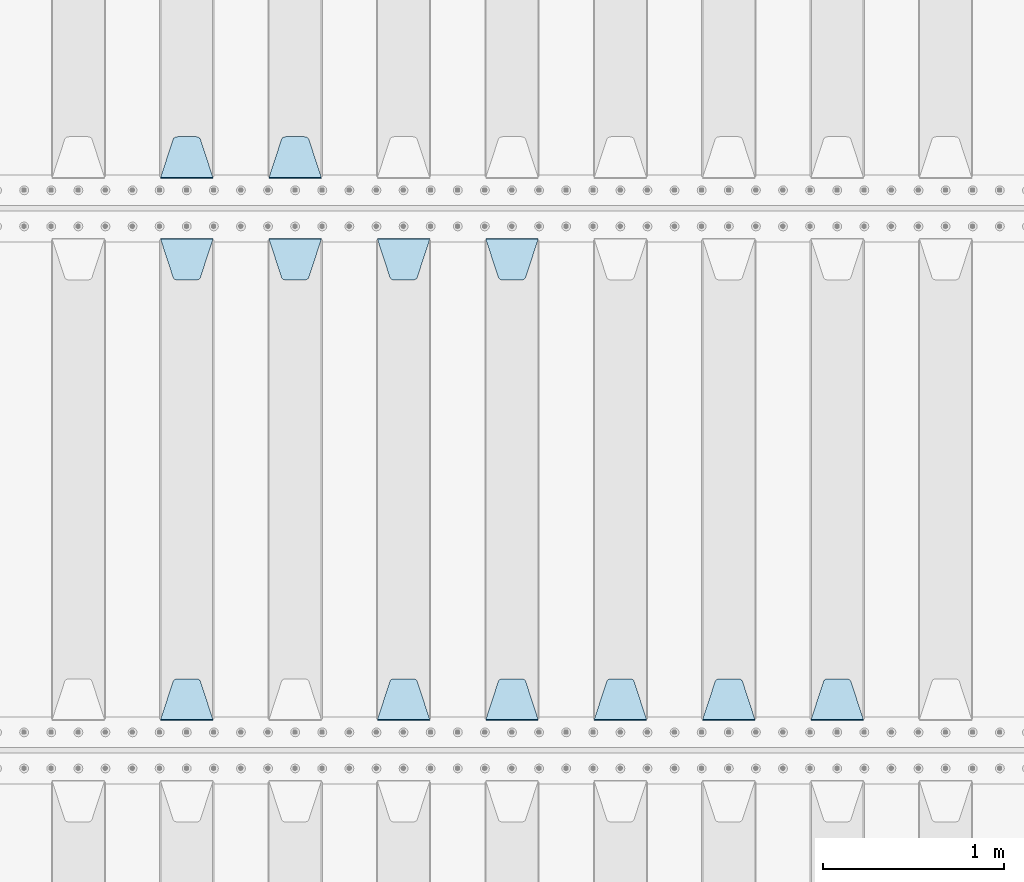
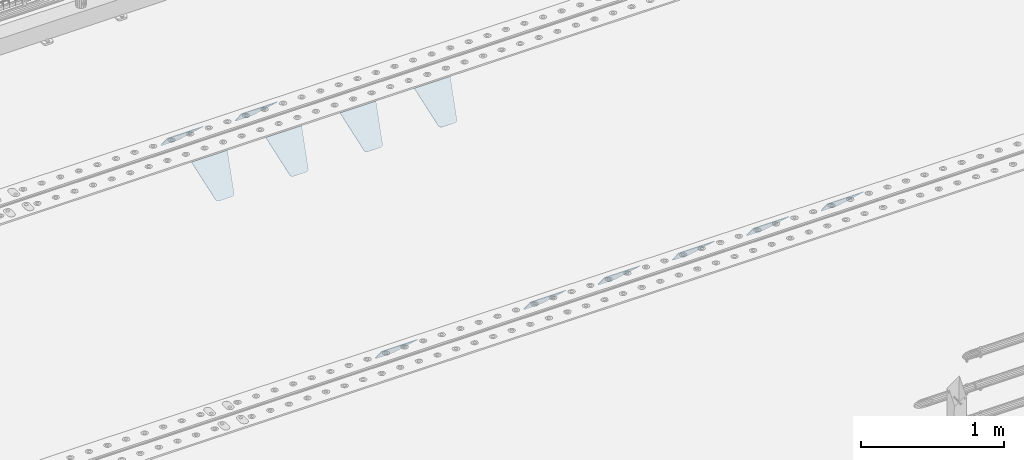
# One storey, part 208 of 247: 12 plates.
"""IFC2X3 building model written with IfcOpenShell, lengths in millimetres."""

from ifc_helpers import new_model, si_unit, frame, origin_with_axes, place, context, subcontext, project, spatial, faceted_brep, material, type_object, element, save


model = new_model("IFC2X3")

# Units and contexts
model_context = context("Model", 3, precision=1e-05, world=origin_with_axes())
body_context = subcontext(model_context, "Body", "Model", "MODEL_VIEW")
ifc_project = project(units=[si_unit("LENGTHUNIT", "METRE", prefix="MILLI"), si_unit("AREAUNIT", "SQUARE_METRE"), si_unit("VOLUMEUNIT", "CUBIC_METRE"), si_unit("MASSUNIT", "GRAM", prefix="KILO"), si_unit("TIMEUNIT", "SECOND"), si_unit("PLANEANGLEUNIT", "RADIAN"), si_unit("SOLIDANGLEUNIT", "STERADIAN"), si_unit("THERMODYNAMICTEMPERATUREUNIT", "DEGREE_CELSIUS"), si_unit("LUMINOUSINTENSITYUNIT", "LUMEN")], contexts=[model_context])

# Site, building, storey
site_placement = place(None, origin_with_axes())
site = spatial("IfcSite", under=ifc_project, at=site_placement, CompositionType="ELEMENT")
building_placement = place(site_placement, origin_with_axes())
building = spatial("IfcBuilding", under=site, at=building_placement, Name="Standard", CompositionType="ELEMENT")
storey_placement = place(building_placement, origin_with_axes())
storey = spatial("IfcBuildingStorey", under=building, at=storey_placement, Name="Undefined", CompositionType="ELEMENT", Elevation=0.0)

# Plates
ifc_material = material(Name="STEEL/S355N")
plate_type = type_object("IfcPlateType", PredefinedType="NOTDEFINED")
plate_1_placement = place(storey_placement, frame((10745.0, 3168.23223304703, -1.76776695296758), z_axis=(0.0, 0.707106781186548, -0.707106781186547), x_axis=(-1.0, 0.0, 0.0)))
element("IfcPlate", 1, at=plate_1_placement, inside=storey, type_object=plate_type, material=ifc_material, context=body_context, shape_type="Brep", body=[
    faceted_brep([(0.0, -2.49999999999909, 0.0), (69.345504679477, -2.5, 300.17173142483), (69.345504679477, 2.50000000000091, 300.171731424831), (0.0, 2.5, -9.09494701772928e-13), (70.9274061199576, -2.5, 304.897442415399), (70.9274061199576, 2.50000000000091, 304.8974424154), (73.3818627772307, -2.49999999999909, 309.234538108527), (73.3818627772307, 2.5, 309.234538108526), (76.6187032999551, -2.5, 313.023683126102), (76.6187032999551, 2.50000000000091, 313.023683126102), (80.5190132704993, -2.49999999999909, 316.125672595371), (80.5190132704993, 2.50000000000091, 316.125672595372), (84.9395038596849, -2.49999999999909, 318.426546230476), (84.9395038596849, 2.5, 318.426546230475), (89.7177759439219, -2.5, 319.841774983274), (89.7177759439219, 2.50000000000091, 319.841774983275), (94.678286292652, -2.5, 320.319366455077), (94.678286292652, 2.50000000000091, 320.319366455077), (195.321713707348, -2.5, 320.319366455077), (195.321713707348, 2.50000000000091, 320.319366455077), (200.282224056078, -2.5, 319.841774983274), (200.282224056078, 2.50000000000091, 319.841774983275), (205.060496140315, -2.5, 318.426546230475), (205.060496140315, 2.5, 318.426546230474), (209.480986729501, -2.49999999999818, 316.12567259537), (209.480986729501, 2.50000000000091, 316.12567259537), (213.381296700045, -2.5, 313.023683126101), (213.381296700045, 2.50000000000091, 313.023683126101), (216.618137222769, -2.5, 309.234538108525), (216.618137222769, 2.5, 309.234538108525), (219.072593880042, -2.49999999999909, 304.897442415398), (219.072593880042, 2.5, 304.897442415398), (220.654495320523, -2.5, 300.17173142483), (220.654495320523, 2.50000000000091, 300.171731424831), (290.0, -2.49999999999909, 0.0), (290.0, 2.5, -9.09494701772928e-13)], [[[0, 1, 2, 3]], [[1, 4, 5, 2]], [[4, 6, 7, 5]], [[6, 8, 9, 7]], [[8, 10, 11, 9]], [[10, 12, 13, 11]], [[12, 14, 15, 13]], [[14, 16, 17, 15]], [[16, 18, 19, 17]], [[18, 20, 21, 19]], [[20, 22, 23, 21]], [[22, 24, 25, 23]], [[24, 26, 27, 25]], [[26, 28, 29, 27]], [[28, 30, 31, 29]], [[30, 32, 33, 31]], [[32, 34, 35, 33]], [[34, 0, 3, 35]], [[5, 7, 9, 11, 13, 15, 17, 19, 21, 23, 25, 27, 29, 31, 33, 35, 3, 2]], [[34, 32, 30, 28, 26, 24, 22, 20, 18, 16, 14, 12, 10, 8, 6, 4, 1, 0]]]),
])
plate_2_placement = place(storey_placement, frame((10145.0, 3168.23223304703, -1.76776695296758), z_axis=(0.0, 0.707106781186548, -0.707106781186547), x_axis=(-1.0, 0.0, 0.0)))
element("IfcPlate", 2, at=plate_2_placement, inside=storey, type_object=plate_type, material=ifc_material, context=body_context, shape_type="Brep", body=[
    faceted_brep([(0.0, -2.49999999999909, 0.0), (69.345504679477, -2.5, 300.17173142483), (69.345504679477, 2.50000000000091, 300.171731424831), (0.0, 2.5, -9.09494701772928e-13), (70.9274061199576, -2.5, 304.897442415399), (70.9274061199576, 2.50000000000091, 304.8974424154), (73.3818627772307, -2.49999999999909, 309.234538108527), (73.3818627772307, 2.5, 309.234538108526), (76.6187032999551, -2.5, 313.023683126102), (76.6187032999551, 2.50000000000091, 313.023683126102), (80.5190132704993, -2.49999999999909, 316.125672595371), (80.5190132704993, 2.50000000000091, 316.125672595372), (84.9395038596849, -2.49999999999909, 318.426546230476), (84.9395038596849, 2.5, 318.426546230475), (89.7177759439219, -2.5, 319.841774983274), (89.7177759439219, 2.50000000000091, 319.841774983275), (94.678286292652, -2.5, 320.319366455077), (94.678286292652, 2.50000000000091, 320.319366455077), (195.321713707348, -2.5, 320.319366455077), (195.321713707348, 2.50000000000091, 320.319366455077), (200.282224056078, -2.5, 319.841774983274), (200.282224056078, 2.50000000000091, 319.841774983275), (205.060496140315, -2.5, 318.426546230475), (205.060496140315, 2.5, 318.426546230474), (209.480986729501, -2.49999999999818, 316.12567259537), (209.480986729501, 2.50000000000091, 316.12567259537), (213.381296700045, -2.5, 313.023683126101), (213.381296700045, 2.50000000000091, 313.023683126101), (216.618137222769, -2.5, 309.234538108525), (216.618137222769, 2.5, 309.234538108525), (219.072593880042, -2.49999999999909, 304.897442415398), (219.072593880042, 2.5, 304.897442415398), (220.654495320523, -2.5, 300.17173142483), (220.654495320523, 2.50000000000091, 300.171731424831), (290.0, -2.49999999999909, 0.0), (290.0, 2.5, -9.09494701772928e-13)], [[[0, 1, 2, 3]], [[1, 4, 5, 2]], [[4, 6, 7, 5]], [[6, 8, 9, 7]], [[8, 10, 11, 9]], [[10, 12, 13, 11]], [[12, 14, 15, 13]], [[14, 16, 17, 15]], [[16, 18, 19, 17]], [[18, 20, 21, 19]], [[20, 22, 23, 21]], [[22, 24, 25, 23]], [[24, 26, 27, 25]], [[26, 28, 29, 27]], [[28, 30, 31, 29]], [[30, 32, 33, 31]], [[32, 34, 35, 33]], [[34, 0, 3, 35]], [[5, 7, 9, 11, 13, 15, 17, 19, 21, 23, 25, 27, 29, 31, 33, 35, 3, 2]], [[34, 32, 30, 28, 26, 24, 22, 20, 18, 16, 14, 12, 10, 8, 6, 4, 1, 0]]]),
])
plate_3_placement = place(storey_placement, frame((9545.0, 3168.23223304703, -1.76776695296758), z_axis=(0.0, 0.707106781186548, -0.707106781186547), x_axis=(-1.0, 0.0, 0.0)))
element("IfcPlate", 3, at=plate_3_placement, inside=storey, type_object=plate_type, material=ifc_material, context=body_context, shape_type="Brep", body=[
    faceted_brep([(0.0, -2.49999999999909, 0.0), (69.345504679477, -2.5, 300.17173142483), (69.345504679477, 2.50000000000091, 300.171731424831), (0.0, 2.5, -9.09494701772928e-13), (70.9274061199576, -2.5, 304.897442415399), (70.9274061199576, 2.50000000000091, 304.8974424154), (73.3818627772307, -2.49999999999909, 309.234538108527), (73.3818627772307, 2.5, 309.234538108526), (76.6187032999551, -2.5, 313.023683126102), (76.6187032999551, 2.50000000000091, 313.023683126102), (80.5190132704993, -2.49999999999909, 316.125672595371), (80.5190132704993, 2.50000000000091, 316.125672595372), (84.9395038596849, -2.49999999999909, 318.426546230476), (84.9395038596849, 2.5, 318.426546230475), (89.7177759439219, -2.5, 319.841774983274), (89.7177759439219, 2.50000000000091, 319.841774983275), (94.678286292652, -2.5, 320.319366455077), (94.678286292652, 2.50000000000091, 320.319366455077), (195.321713707348, -2.5, 320.319366455077), (195.321713707348, 2.50000000000091, 320.319366455077), (200.282224056078, -2.5, 319.841774983274), (200.282224056078, 2.50000000000091, 319.841774983275), (205.060496140315, -2.5, 318.426546230475), (205.060496140315, 2.5, 318.426546230474), (209.480986729501, -2.49999999999818, 316.12567259537), (209.480986729501, 2.50000000000091, 316.12567259537), (213.381296700045, -2.5, 313.023683126101), (213.381296700045, 2.50000000000091, 313.023683126101), (216.618137222769, -2.5, 309.234538108525), (216.618137222769, 2.5, 309.234538108525), (219.072593880042, -2.49999999999909, 304.897442415398), (219.072593880042, 2.5, 304.897442415398), (220.654495320523, -2.5, 300.17173142483), (220.654495320523, 2.50000000000091, 300.171731424831), (290.0, -2.49999999999909, 0.0), (290.0, 2.5, -9.09494701772928e-13)], [[[0, 1, 2, 3]], [[1, 4, 5, 2]], [[4, 6, 7, 5]], [[6, 8, 9, 7]], [[8, 10, 11, 9]], [[10, 12, 13, 11]], [[12, 14, 15, 13]], [[14, 16, 17, 15]], [[16, 18, 19, 17]], [[18, 20, 21, 19]], [[20, 22, 23, 21]], [[22, 24, 25, 23]], [[24, 26, 27, 25]], [[26, 28, 29, 27]], [[28, 30, 31, 29]], [[30, 32, 33, 31]], [[32, 34, 35, 33]], [[34, 0, 3, 35]], [[5, 7, 9, 11, 13, 15, 17, 19, 21, 23, 25, 27, 29, 31, 33, 35, 3, 2]], [[34, 32, 30, 28, 26, 24, 22, 20, 18, 16, 14, 12, 10, 8, 6, 4, 1, 0]]]),
])
plate_4_placement = place(storey_placement, frame((8655.0, 5831.76776695594, -1.767766952965), z_axis=(0.0, -0.707106781186548, -0.707106781186547), x_axis=(1.0, 0.0, 0.0)))
element("IfcPlate", 4, at=plate_4_placement, inside=storey, type_object=plate_type, material=ifc_material, context=body_context, shape_type="Brep", body=[
    faceted_brep([(0.0, -2.49999999999909, 0.0), (69.345504679477, -2.5, 300.17173142483), (69.345504679477, 2.50000000000091, 300.171731424831), (0.0, 2.5, -9.09494701772928e-13), (70.9274061199576, -2.5, 304.897442415399), (70.9274061199576, 2.50000000000091, 304.8974424154), (73.3818627772307, -2.49999999999909, 309.234538108527), (73.3818627772307, 2.5, 309.234538108526), (76.6187032999551, -2.5, 313.023683126102), (76.6187032999551, 2.50000000000091, 313.023683126102), (80.5190132704993, -2.49999999999909, 316.125672595371), (80.5190132704993, 2.50000000000091, 316.125672595372), (84.9395038596849, -2.49999999999909, 318.426546230476), (84.9395038596849, 2.5, 318.426546230475), (89.7177759439219, -2.5, 319.841774983274), (89.7177759439219, 2.50000000000091, 319.841774983275), (94.678286292652, -2.5, 320.319366455077), (94.678286292652, 2.50000000000091, 320.319366455077), (195.321713707348, -2.5, 320.319366455077), (195.321713707348, 2.50000000000091, 320.319366455077), (200.282224056078, -2.5, 319.841774983274), (200.282224056078, 2.50000000000091, 319.841774983275), (205.060496140315, -2.5, 318.426546230475), (205.060496140315, 2.5, 318.426546230474), (209.480986729501, -2.49999999999818, 316.12567259537), (209.480986729501, 2.50000000000091, 316.12567259537), (213.381296700045, -2.5, 313.023683126101), (213.381296700045, 2.50000000000091, 313.023683126101), (216.618137222769, -2.5, 309.234538108525), (216.618137222769, 2.5, 309.234538108525), (219.072593880042, -2.49999999999909, 304.897442415398), (219.072593880042, 2.5, 304.897442415398), (220.654495320523, -2.5, 300.17173142483), (220.654495320523, 2.50000000000091, 300.171731424831), (290.0, -2.49999999999909, 0.0), (290.0, 2.5, -9.09494701772928e-13)], [[[0, 1, 2, 3]], [[1, 4, 5, 2]], [[4, 6, 7, 5]], [[6, 8, 9, 7]], [[8, 10, 11, 9]], [[10, 12, 13, 11]], [[12, 14, 15, 13]], [[14, 16, 17, 15]], [[16, 18, 19, 17]], [[18, 20, 21, 19]], [[20, 22, 23, 21]], [[22, 24, 25, 23]], [[24, 26, 27, 25]], [[26, 28, 29, 27]], [[28, 30, 31, 29]], [[30, 32, 33, 31]], [[32, 34, 35, 33]], [[34, 0, 3, 35]], [[5, 7, 9, 11, 13, 15, 17, 19, 21, 23, 25, 27, 29, 31, 33, 35, 3, 2]], [[34, 32, 30, 28, 26, 24, 22, 20, 18, 16, 14, 12, 10, 8, 6, 4, 1, 0]]]),
])
plate_5_placement = place(storey_placement, frame((8945.0, 3168.23223304703, -1.76776695296758), z_axis=(0.0, 0.707106781186548, -0.707106781186547), x_axis=(-1.0, 0.0, 0.0)))
element("IfcPlate", 5, at=plate_5_placement, inside=storey, type_object=plate_type, material=ifc_material, context=body_context, shape_type="Brep", body=[
    faceted_brep([(0.0, -2.49999999999909, 0.0), (69.345504679477, -2.5, 300.17173142483), (69.345504679477, 2.50000000000091, 300.171731424831), (0.0, 2.5, -9.09494701772928e-13), (70.9274061199576, -2.5, 304.897442415399), (70.9274061199576, 2.50000000000091, 304.8974424154), (73.3818627772307, -2.49999999999909, 309.234538108527), (73.3818627772307, 2.5, 309.234538108526), (76.6187032999551, -2.5, 313.023683126102), (76.6187032999551, 2.50000000000091, 313.023683126102), (80.5190132704993, -2.49999999999909, 316.125672595371), (80.5190132704993, 2.50000000000091, 316.125672595372), (84.9395038596849, -2.49999999999909, 318.426546230476), (84.9395038596849, 2.5, 318.426546230475), (89.7177759439219, -2.5, 319.841774983274), (89.7177759439219, 2.50000000000091, 319.841774983275), (94.678286292652, -2.5, 320.319366455077), (94.678286292652, 2.50000000000091, 320.319366455077), (195.321713707348, -2.5, 320.319366455077), (195.321713707348, 2.50000000000091, 320.319366455077), (200.282224056078, -2.5, 319.841774983274), (200.282224056078, 2.50000000000091, 319.841774983275), (205.060496140315, -2.5, 318.426546230475), (205.060496140315, 2.5, 318.426546230474), (209.480986729501, -2.49999999999818, 316.12567259537), (209.480986729501, 2.50000000000091, 316.12567259537), (213.381296700045, -2.5, 313.023683126101), (213.381296700045, 2.50000000000091, 313.023683126101), (216.618137222769, -2.5, 309.234538108525), (216.618137222769, 2.5, 309.234538108525), (219.072593880042, -2.49999999999909, 304.897442415398), (219.072593880042, 2.5, 304.897442415398), (220.654495320523, -2.5, 300.17173142483), (220.654495320523, 2.50000000000091, 300.171731424831), (290.0, -2.49999999999909, 0.0), (290.0, 2.5, -9.09494701772928e-13)], [[[0, 1, 2, 3]], [[1, 4, 5, 2]], [[4, 6, 7, 5]], [[6, 8, 9, 7]], [[8, 10, 11, 9]], [[10, 12, 13, 11]], [[12, 14, 15, 13]], [[14, 16, 17, 15]], [[16, 18, 19, 17]], [[18, 20, 21, 19]], [[20, 22, 23, 21]], [[22, 24, 25, 23]], [[24, 26, 27, 25]], [[26, 28, 29, 27]], [[28, 30, 31, 29]], [[30, 32, 33, 31]], [[32, 34, 35, 33]], [[34, 0, 3, 35]], [[5, 7, 9, 11, 13, 15, 17, 19, 21, 23, 25, 27, 29, 31, 33, 35, 3, 2]], [[34, 32, 30, 28, 26, 24, 22, 20, 18, 16, 14, 12, 10, 8, 6, 4, 1, 0]]]),
])
plate_6_placement = place(storey_placement, frame((8055.0, 5831.76776695594, -1.767766952965), z_axis=(0.0, -0.707106781186548, -0.707106781186547), x_axis=(1.0, 0.0, 0.0)))
element("IfcPlate", 6, at=plate_6_placement, inside=storey, type_object=plate_type, material=ifc_material, context=body_context, shape_type="Brep", body=[
    faceted_brep([(0.0, -2.49999999999909, 0.0), (69.345504679477, -2.5, 300.17173142483), (69.345504679477, 2.50000000000091, 300.171731424831), (0.0, 2.5, -9.09494701772928e-13), (70.9274061199576, -2.5, 304.897442415399), (70.9274061199576, 2.50000000000091, 304.8974424154), (73.3818627772307, -2.49999999999909, 309.234538108527), (73.3818627772307, 2.5, 309.234538108526), (76.6187032999551, -2.5, 313.023683126102), (76.6187032999551, 2.50000000000091, 313.023683126102), (80.5190132704993, -2.49999999999909, 316.125672595371), (80.5190132704993, 2.50000000000091, 316.125672595372), (84.9395038596849, -2.49999999999909, 318.426546230476), (84.9395038596849, 2.5, 318.426546230475), (89.7177759439219, -2.5, 319.841774983274), (89.7177759439219, 2.50000000000091, 319.841774983275), (94.678286292652, -2.5, 320.319366455077), (94.678286292652, 2.50000000000091, 320.319366455077), (195.321713707348, -2.5, 320.319366455077), (195.321713707348, 2.50000000000091, 320.319366455077), (200.282224056078, -2.5, 319.841774983274), (200.282224056078, 2.50000000000091, 319.841774983275), (205.060496140315, -2.5, 318.426546230475), (205.060496140315, 2.5, 318.426546230474), (209.480986729501, -2.49999999999818, 316.12567259537), (209.480986729501, 2.50000000000091, 316.12567259537), (213.381296700045, -2.5, 313.023683126101), (213.381296700045, 2.50000000000091, 313.023683126101), (216.618137222769, -2.5, 309.234538108525), (216.618137222769, 2.5, 309.234538108525), (219.072593880042, -2.49999999999909, 304.897442415398), (219.072593880042, 2.5, 304.897442415398), (220.654495320523, -2.5, 300.17173142483), (220.654495320523, 2.50000000000091, 300.171731424831), (290.0, -2.49999999999909, 0.0), (290.0, 2.5, -9.09494701772928e-13)], [[[0, 1, 2, 3]], [[1, 4, 5, 2]], [[4, 6, 7, 5]], [[6, 8, 9, 7]], [[8, 10, 11, 9]], [[10, 12, 13, 11]], [[12, 14, 15, 13]], [[14, 16, 17, 15]], [[16, 18, 19, 17]], [[18, 20, 21, 19]], [[20, 22, 23, 21]], [[22, 24, 25, 23]], [[24, 26, 27, 25]], [[26, 28, 29, 27]], [[28, 30, 31, 29]], [[30, 32, 33, 31]], [[32, 34, 35, 33]], [[34, 0, 3, 35]], [[5, 7, 9, 11, 13, 15, 17, 19, 21, 23, 25, 27, 29, 31, 33, 35, 3, 2]], [[34, 32, 30, 28, 26, 24, 22, 20, 18, 16, 14, 12, 10, 8, 6, 4, 1, 0]]]),
])
plate_7_placement = place(storey_placement, frame((8345.0, 3168.23223304703, -1.76776695296758), z_axis=(0.0, 0.707106781186548, -0.707106781186547), x_axis=(-1.0, 0.0, 0.0)))
element("IfcPlate", 7, at=plate_7_placement, inside=storey, type_object=plate_type, material=ifc_material, context=body_context, shape_type="Brep", body=[
    faceted_brep([(0.0, -2.49999999999909, 0.0), (69.345504679477, -2.5, 300.17173142483), (69.345504679477, 2.50000000000091, 300.171731424831), (0.0, 2.5, -9.09494701772928e-13), (70.9274061199576, -2.5, 304.897442415399), (70.9274061199576, 2.50000000000091, 304.8974424154), (73.3818627772307, -2.49999999999909, 309.234538108527), (73.3818627772307, 2.5, 309.234538108526), (76.6187032999551, -2.5, 313.023683126102), (76.6187032999551, 2.50000000000091, 313.023683126102), (80.5190132704993, -2.49999999999909, 316.125672595371), (80.5190132704993, 2.50000000000091, 316.125672595372), (84.9395038596849, -2.49999999999909, 318.426546230476), (84.9395038596849, 2.5, 318.426546230475), (89.7177759439219, -2.5, 319.841774983274), (89.7177759439219, 2.50000000000091, 319.841774983275), (94.678286292652, -2.5, 320.319366455077), (94.678286292652, 2.50000000000091, 320.319366455077), (195.321713707348, -2.5, 320.319366455077), (195.321713707348, 2.50000000000091, 320.319366455077), (200.282224056078, -2.5, 319.841774983274), (200.282224056078, 2.50000000000091, 319.841774983275), (205.060496140315, -2.5, 318.426546230475), (205.060496140315, 2.5, 318.426546230474), (209.480986729501, -2.49999999999818, 316.12567259537), (209.480986729501, 2.50000000000091, 316.12567259537), (213.381296700045, -2.5, 313.023683126101), (213.381296700045, 2.50000000000091, 313.023683126101), (216.618137222769, -2.5, 309.234538108525), (216.618137222769, 2.5, 309.234538108525), (219.072593880042, -2.49999999999909, 304.897442415398), (219.072593880042, 2.5, 304.897442415398), (220.654495320523, -2.5, 300.17173142483), (220.654495320523, 2.50000000000091, 300.171731424831), (290.0, -2.49999999999909, 0.0), (290.0, 2.5, -9.09494701772928e-13)], [[[0, 1, 2, 3]], [[1, 4, 5, 2]], [[4, 6, 7, 5]], [[6, 8, 9, 7]], [[8, 10, 11, 9]], [[10, 12, 13, 11]], [[12, 14, 15, 13]], [[14, 16, 17, 15]], [[16, 18, 19, 17]], [[18, 20, 21, 19]], [[20, 22, 23, 21]], [[22, 24, 25, 23]], [[24, 26, 27, 25]], [[26, 28, 29, 27]], [[28, 30, 31, 29]], [[30, 32, 33, 31]], [[32, 34, 35, 33]], [[34, 0, 3, 35]], [[5, 7, 9, 11, 13, 15, 17, 19, 21, 23, 25, 27, 29, 31, 33, 35, 3, 2]], [[34, 32, 30, 28, 26, 24, 22, 20, 18, 16, 14, 12, 10, 8, 6, 4, 1, 0]]]),
])
plate_8_placement = place(storey_placement, frame((7455.0, 5831.76776695594, -1.767766952965), z_axis=(0.0, -0.707106781186548, -0.707106781186547), x_axis=(1.0, 0.0, 0.0)))
element("IfcPlate", 8, at=plate_8_placement, inside=storey, type_object=plate_type, material=ifc_material, context=body_context, shape_type="Brep", body=[
    faceted_brep([(0.0, -2.49999999999909, 0.0), (69.345504679477, -2.5, 300.17173142483), (69.345504679477, 2.50000000000091, 300.171731424831), (0.0, 2.5, -9.09494701772928e-13), (70.9274061199576, -2.5, 304.897442415399), (70.9274061199576, 2.50000000000091, 304.8974424154), (73.3818627772307, -2.49999999999909, 309.234538108527), (73.3818627772307, 2.5, 309.234538108526), (76.6187032999551, -2.5, 313.023683126102), (76.6187032999551, 2.50000000000091, 313.023683126102), (80.5190132704993, -2.49999999999909, 316.125672595371), (80.5190132704993, 2.50000000000091, 316.125672595372), (84.9395038596849, -2.49999999999909, 318.426546230476), (84.9395038596849, 2.5, 318.426546230475), (89.7177759439219, -2.5, 319.841774983274), (89.7177759439219, 2.50000000000091, 319.841774983275), (94.678286292652, -2.5, 320.319366455077), (94.678286292652, 2.50000000000091, 320.319366455077), (195.321713707348, -2.5, 320.319366455077), (195.321713707348, 2.50000000000091, 320.319366455077), (200.282224056078, -2.5, 319.841774983274), (200.282224056078, 2.50000000000091, 319.841774983275), (205.060496140315, -2.5, 318.426546230475), (205.060496140315, 2.5, 318.426546230474), (209.480986729501, -2.49999999999818, 316.12567259537), (209.480986729501, 2.50000000000091, 316.12567259537), (213.381296700045, -2.5, 313.023683126101), (213.381296700045, 2.50000000000091, 313.023683126101), (216.618137222769, -2.5, 309.234538108525), (216.618137222769, 2.5, 309.234538108525), (219.072593880042, -2.49999999999909, 304.897442415398), (219.072593880042, 2.5, 304.897442415398), (220.654495320523, -2.5, 300.17173142483), (220.654495320523, 2.50000000000091, 300.171731424831), (290.0, -2.49999999999909, 0.0), (290.0, 2.5, -9.09494701772928e-13)], [[[0, 1, 2, 3]], [[1, 4, 5, 2]], [[4, 6, 7, 5]], [[6, 8, 9, 7]], [[8, 10, 11, 9]], [[10, 12, 13, 11]], [[12, 14, 15, 13]], [[14, 16, 17, 15]], [[16, 18, 19, 17]], [[18, 20, 21, 19]], [[20, 22, 23, 21]], [[22, 24, 25, 23]], [[24, 26, 27, 25]], [[26, 28, 29, 27]], [[28, 30, 31, 29]], [[30, 32, 33, 31]], [[32, 34, 35, 33]], [[34, 0, 3, 35]], [[5, 7, 9, 11, 13, 15, 17, 19, 21, 23, 25, 27, 29, 31, 33, 35, 3, 2]], [[34, 32, 30, 28, 26, 24, 22, 20, 18, 16, 14, 12, 10, 8, 6, 4, 1, 0]]]),
])
plate_9_placement = place(storey_placement, frame((6855.0, 5831.76776695594, -1.767766952965), z_axis=(0.0, -0.707106781186548, -0.707106781186547), x_axis=(1.0, 0.0, 0.0)))
element("IfcPlate", 9, at=plate_9_placement, inside=storey, type_object=plate_type, material=ifc_material, context=body_context, shape_type="Brep", body=[
    faceted_brep([(0.0, -2.49999999999909, 0.0), (69.345504679477, -2.5, 300.17173142483), (69.345504679477, 2.50000000000091, 300.171731424831), (0.0, 2.5, -9.09494701772928e-13), (70.9274061199576, -2.5, 304.897442415399), (70.9274061199576, 2.50000000000091, 304.8974424154), (73.3818627772307, -2.49999999999909, 309.234538108527), (73.3818627772307, 2.5, 309.234538108526), (76.6187032999551, -2.5, 313.023683126102), (76.6187032999551, 2.50000000000091, 313.023683126102), (80.5190132704993, -2.49999999999909, 316.125672595371), (80.5190132704993, 2.50000000000091, 316.125672595372), (84.9395038596849, -2.49999999999909, 318.426546230476), (84.9395038596849, 2.5, 318.426546230475), (89.7177759439219, -2.5, 319.841774983274), (89.7177759439219, 2.50000000000091, 319.841774983275), (94.678286292652, -2.5, 320.319366455077), (94.678286292652, 2.50000000000091, 320.319366455077), (195.321713707348, -2.5, 320.319366455077), (195.321713707348, 2.50000000000091, 320.319366455077), (200.282224056078, -2.5, 319.841774983274), (200.282224056078, 2.50000000000091, 319.841774983275), (205.060496140315, -2.5, 318.426546230475), (205.060496140315, 2.5, 318.426546230474), (209.480986729501, -2.49999999999818, 316.12567259537), (209.480986729501, 2.50000000000091, 316.12567259537), (213.381296700045, -2.5, 313.023683126101), (213.381296700045, 2.50000000000091, 313.023683126101), (216.618137222769, -2.5, 309.234538108525), (216.618137222769, 2.5, 309.234538108525), (219.072593880042, -2.49999999999909, 304.897442415398), (219.072593880042, 2.5, 304.897442415398), (220.654495320523, -2.5, 300.17173142483), (220.654495320523, 2.50000000000091, 300.171731424831), (290.0, -2.49999999999909, 0.0), (290.0, 2.5, -9.09494701772928e-13)], [[[0, 1, 2, 3]], [[1, 4, 5, 2]], [[4, 6, 7, 5]], [[6, 8, 9, 7]], [[8, 10, 11, 9]], [[10, 12, 13, 11]], [[12, 14, 15, 13]], [[14, 16, 17, 15]], [[16, 18, 19, 17]], [[18, 20, 21, 19]], [[20, 22, 23, 21]], [[22, 24, 25, 23]], [[24, 26, 27, 25]], [[26, 28, 29, 27]], [[28, 30, 31, 29]], [[30, 32, 33, 31]], [[32, 34, 35, 33]], [[34, 0, 3, 35]], [[5, 7, 9, 11, 13, 15, 17, 19, 21, 23, 25, 27, 29, 31, 33, 35, 3, 2]], [[34, 32, 30, 28, 26, 24, 22, 20, 18, 16, 14, 12, 10, 8, 6, 4, 1, 0]]]),
])
plate_10_placement = place(storey_placement, frame((7145.0, 3168.23223304703, -1.76776695296758), z_axis=(0.0, 0.707106781186548, -0.707106781186547), x_axis=(-1.0, 0.0, 0.0)))
element("IfcPlate", 10, at=plate_10_placement, inside=storey, type_object=plate_type, material=ifc_material, context=body_context, shape_type="Brep", body=[
    faceted_brep([(0.0, -2.49999999999909, 0.0), (69.345504679477, -2.5, 300.17173142483), (69.345504679477, 2.50000000000091, 300.171731424831), (0.0, 2.5, -9.09494701772928e-13), (70.9274061199576, -2.5, 304.897442415399), (70.9274061199576, 2.50000000000091, 304.8974424154), (73.3818627772307, -2.49999999999909, 309.234538108527), (73.3818627772307, 2.5, 309.234538108526), (76.6187032999551, -2.5, 313.023683126102), (76.6187032999551, 2.50000000000091, 313.023683126102), (80.5190132704993, -2.49999999999909, 316.125672595371), (80.5190132704993, 2.50000000000091, 316.125672595372), (84.9395038596849, -2.49999999999909, 318.426546230476), (84.9395038596849, 2.5, 318.426546230475), (89.7177759439219, -2.5, 319.841774983274), (89.7177759439219, 2.50000000000091, 319.841774983275), (94.678286292652, -2.5, 320.319366455077), (94.678286292652, 2.50000000000091, 320.319366455077), (195.321713707348, -2.5, 320.319366455077), (195.321713707348, 2.50000000000091, 320.319366455077), (200.282224056078, -2.5, 319.841774983274), (200.282224056078, 2.50000000000091, 319.841774983275), (205.060496140315, -2.5, 318.426546230475), (205.060496140315, 2.5, 318.426546230474), (209.480986729501, -2.49999999999818, 316.12567259537), (209.480986729501, 2.50000000000091, 316.12567259537), (213.381296700045, -2.5, 313.023683126101), (213.381296700045, 2.50000000000091, 313.023683126101), (216.618137222769, -2.5, 309.234538108525), (216.618137222769, 2.5, 309.234538108525), (219.072593880042, -2.49999999999909, 304.897442415398), (219.072593880042, 2.5, 304.897442415398), (220.654495320523, -2.5, 300.17173142483), (220.654495320523, 2.50000000000091, 300.171731424831), (290.0, -2.49999999999909, 0.0), (290.0, 2.5, -9.09494701772928e-13)], [[[0, 1, 2, 3]], [[1, 4, 5, 2]], [[4, 6, 7, 5]], [[6, 8, 9, 7]], [[8, 10, 11, 9]], [[10, 12, 13, 11]], [[12, 14, 15, 13]], [[14, 16, 17, 15]], [[16, 18, 19, 17]], [[18, 20, 21, 19]], [[20, 22, 23, 21]], [[22, 24, 25, 23]], [[24, 26, 27, 25]], [[26, 28, 29, 27]], [[28, 30, 31, 29]], [[30, 32, 33, 31]], [[32, 34, 35, 33]], [[34, 0, 3, 35]], [[5, 7, 9, 11, 13, 15, 17, 19, 21, 23, 25, 27, 29, 31, 33, 35, 3, 2]], [[34, 32, 30, 28, 26, 24, 22, 20, 18, 16, 14, 12, 10, 8, 6, 4, 1, 0]]]),
])
plate_11_placement = place(storey_placement, frame((7745.0, 6168.23223304703, -1.76776695296758), z_axis=(0.0, 0.707106781186548, -0.707106781186547), x_axis=(-1.0, 0.0, 0.0)))
element("IfcPlate", 11, at=plate_11_placement, inside=storey, type_object=plate_type, material=ifc_material, context=body_context, shape_type="Brep", body=[
    faceted_brep([(0.0, -2.49999999999909, 0.0), (69.345504679477, -2.5, 300.17173142483), (69.345504679477, 2.50000000000091, 300.171731424831), (0.0, 2.5, -9.09494701772928e-13), (70.9274061199576, -2.5, 304.897442415399), (70.9274061199576, 2.50000000000091, 304.8974424154), (73.3818627772307, -2.49999999999909, 309.234538108527), (73.3818627772307, 2.5, 309.234538108526), (76.6187032999551, -2.5, 313.023683126102), (76.6187032999551, 2.50000000000091, 313.023683126102), (80.5190132704993, -2.49999999999909, 316.125672595371), (80.5190132704993, 2.50000000000091, 316.125672595372), (84.9395038596849, -2.49999999999909, 318.426546230476), (84.9395038596849, 2.5, 318.426546230475), (89.7177759439219, -2.5, 319.841774983274), (89.7177759439219, 2.50000000000091, 319.841774983275), (94.678286292652, -2.5, 320.319366455077), (94.678286292652, 2.50000000000091, 320.319366455077), (195.321713707348, -2.5, 320.319366455077), (195.321713707348, 2.50000000000091, 320.319366455077), (200.282224056078, -2.5, 319.841774983274), (200.282224056078, 2.50000000000091, 319.841774983275), (205.060496140315, -2.5, 318.426546230475), (205.060496140315, 2.5, 318.426546230474), (209.480986729501, -2.49999999999818, 316.12567259537), (209.480986729501, 2.50000000000091, 316.12567259537), (213.381296700045, -2.5, 313.023683126101), (213.381296700045, 2.50000000000091, 313.023683126101), (216.618137222769, -2.5, 309.234538108525), (216.618137222769, 2.5, 309.234538108525), (219.072593880042, -2.49999999999909, 304.897442415398), (219.072593880042, 2.5, 304.897442415398), (220.654495320523, -2.5, 300.17173142483), (220.654495320523, 2.50000000000091, 300.171731424831), (290.0, -2.49999999999909, 0.0), (290.0, 2.5, -9.09494701772928e-13)], [[[0, 1, 2, 3]], [[1, 4, 5, 2]], [[4, 6, 7, 5]], [[6, 8, 9, 7]], [[8, 10, 11, 9]], [[10, 12, 13, 11]], [[12, 14, 15, 13]], [[14, 16, 17, 15]], [[16, 18, 19, 17]], [[18, 20, 21, 19]], [[20, 22, 23, 21]], [[22, 24, 25, 23]], [[24, 26, 27, 25]], [[26, 28, 29, 27]], [[28, 30, 31, 29]], [[30, 32, 33, 31]], [[32, 34, 35, 33]], [[34, 0, 3, 35]], [[5, 7, 9, 11, 13, 15, 17, 19, 21, 23, 25, 27, 29, 31, 33, 35, 3, 2]], [[34, 32, 30, 28, 26, 24, 22, 20, 18, 16, 14, 12, 10, 8, 6, 4, 1, 0]]]),
])
plate_12_placement = place(storey_placement, frame((7145.0, 6168.23223304703, -1.76776695296758), z_axis=(0.0, 0.707106781186548, -0.707106781186547), x_axis=(-1.0, 0.0, 0.0)))
element("IfcPlate", 12, at=plate_12_placement, inside=storey, type_object=plate_type, material=ifc_material, context=body_context, shape_type="Brep", body=[
    faceted_brep([(0.0, -2.49999999999909, 0.0), (69.345504679477, -2.5, 300.17173142483), (69.345504679477, 2.50000000000091, 300.171731424831), (0.0, 2.5, -9.09494701772928e-13), (70.9274061199576, -2.5, 304.897442415399), (70.9274061199576, 2.50000000000091, 304.8974424154), (73.3818627772307, -2.49999999999909, 309.234538108527), (73.3818627772307, 2.5, 309.234538108526), (76.6187032999551, -2.5, 313.023683126102), (76.6187032999551, 2.50000000000091, 313.023683126102), (80.5190132704993, -2.49999999999909, 316.125672595371), (80.5190132704993, 2.50000000000091, 316.125672595372), (84.9395038596849, -2.49999999999909, 318.426546230476), (84.9395038596849, 2.5, 318.426546230475), (89.7177759439219, -2.5, 319.841774983274), (89.7177759439219, 2.50000000000091, 319.841774983275), (94.678286292652, -2.5, 320.319366455077), (94.678286292652, 2.50000000000091, 320.319366455077), (195.321713707348, -2.5, 320.319366455077), (195.321713707348, 2.50000000000091, 320.319366455077), (200.282224056078, -2.5, 319.841774983274), (200.282224056078, 2.50000000000091, 319.841774983275), (205.060496140315, -2.5, 318.426546230475), (205.060496140315, 2.5, 318.426546230474), (209.480986729501, -2.49999999999818, 316.12567259537), (209.480986729501, 2.50000000000091, 316.12567259537), (213.381296700045, -2.5, 313.023683126101), (213.381296700045, 2.50000000000091, 313.023683126101), (216.618137222769, -2.5, 309.234538108525), (216.618137222769, 2.5, 309.234538108525), (219.072593880042, -2.49999999999909, 304.897442415398), (219.072593880042, 2.5, 304.897442415398), (220.654495320523, -2.5, 300.17173142483), (220.654495320523, 2.50000000000091, 300.171731424831), (290.0, -2.49999999999909, 0.0), (290.0, 2.5, -9.09494701772928e-13)], [[[0, 1, 2, 3]], [[1, 4, 5, 2]], [[4, 6, 7, 5]], [[6, 8, 9, 7]], [[8, 10, 11, 9]], [[10, 12, 13, 11]], [[12, 14, 15, 13]], [[14, 16, 17, 15]], [[16, 18, 19, 17]], [[18, 20, 21, 19]], [[20, 22, 23, 21]], [[22, 24, 25, 23]], [[24, 26, 27, 25]], [[26, 28, 29, 27]], [[28, 30, 31, 29]], [[30, 32, 33, 31]], [[32, 34, 35, 33]], [[34, 0, 3, 35]], [[5, 7, 9, 11, 13, 15, 17, 19, 21, 23, 25, 27, 29, 31, 33, 35, 3, 2]], [[34, 32, 30, 28, 26, 24, 22, 20, 18, 16, 14, 12, 10, 8, 6, 4, 1, 0]]]),
])

save(model, "model.ifc")
